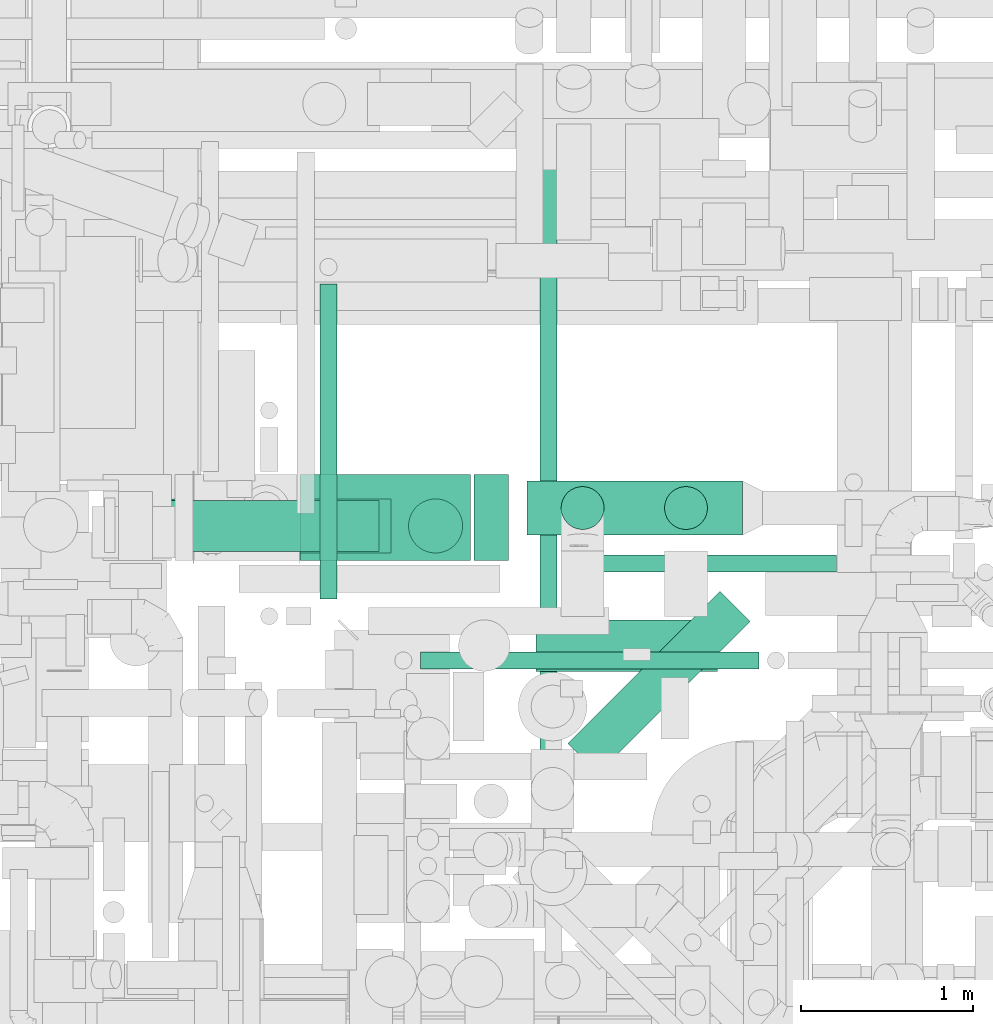
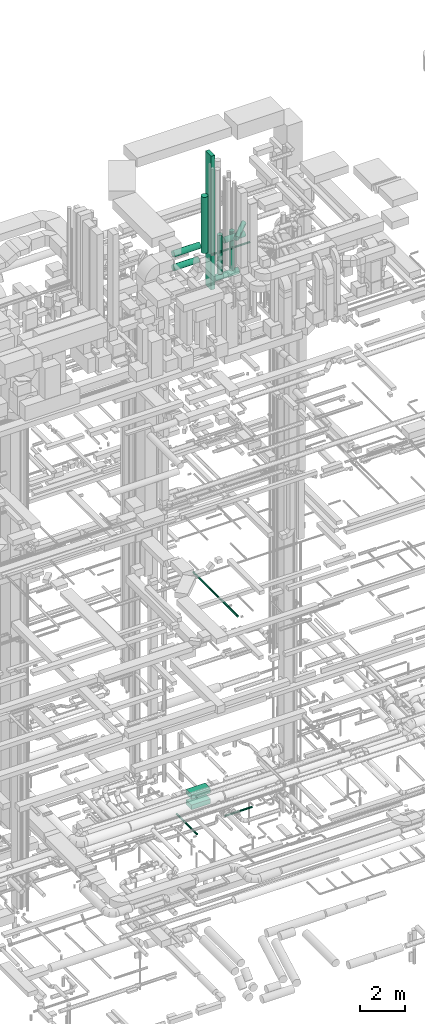
# One storey, part 58 of 337: 15 flow segments.
"""IFC2X3 building model written with IfcOpenShell, lengths in millimetres."""

from ifc_helpers import new_model, entity, si_unit, converted_unit, derived_unit, direction, frame, origin, origin_2d_with_axis, place, context, subcontext, project, spatial, rectangle, circle, extrude, type_object, element, save


model = new_model("IFC2X3")

# Units and contexts
model_context = context("Model", 3, precision=0.01, world=origin(), true_north=direction((6.12303176911189e-17, 1.0)))
body_context = subcontext(model_context, "Body", "Model", "MODEL_VIEW")
ifc_project = project(units=[si_unit("LENGTHUNIT", "METRE", prefix="MILLI"), si_unit("AREAUNIT", "SQUARE_METRE"), si_unit("VOLUMEUNIT", "CUBIC_METRE"), converted_unit("PLANEANGLEUNIT", "DEGREE", entity("IfcRatioMeasure", 0.0174532925199433), si_unit("PLANEANGLEUNIT", "RADIAN"), dimensions=[0, 0, 0, 0, 0, 0, 0]), si_unit("MASSUNIT", "GRAM", prefix="KILO"), derived_unit("MASSDENSITYUNIT", [(si_unit("MASSUNIT", "GRAM", prefix="KILO"), 1), (si_unit("LENGTHUNIT", "METRE"), -3)]), derived_unit("MOMENTOFINERTIAUNIT", [(si_unit("LENGTHUNIT", "METRE"), 4)]), si_unit("TIMEUNIT", "SECOND"), si_unit("FREQUENCYUNIT", "HERTZ"), si_unit("THERMODYNAMICTEMPERATUREUNIT", "DEGREE_CELSIUS"), derived_unit("THERMALTRANSMITTANCEUNIT", [(si_unit("MASSUNIT", "GRAM", prefix="KILO"), 1), (si_unit("THERMODYNAMICTEMPERATUREUNIT", "KELVIN"), -1), (si_unit("TIMEUNIT", "SECOND"), -3)]), derived_unit("VOLUMETRICFLOWRATEUNIT", [(si_unit("LENGTHUNIT", "METRE"), 3), (si_unit("TIMEUNIT", "SECOND"), -1)]), derived_unit("MASSFLOWRATEUNIT", [(si_unit("MASSUNIT", "GRAM", prefix="KILO"), 1), (si_unit("TIMEUNIT", "SECOND"), -1)]), derived_unit("ROTATIONALFREQUENCYUNIT", [(si_unit("TIMEUNIT", "SECOND"), -1)]), si_unit("ELECTRICCURRENTUNIT", "AMPERE"), si_unit("ELECTRICVOLTAGEUNIT", "VOLT"), si_unit("POWERUNIT", "WATT"), si_unit("FORCEUNIT", "NEWTON", prefix="KILO"), si_unit("ILLUMINANCEUNIT", "LUX"), si_unit("LUMINOUSFLUXUNIT", "LUMEN"), si_unit("LUMINOUSINTENSITYUNIT", "CANDELA"), derived_unit("USERDEFINED", [(si_unit("MASSUNIT", "GRAM", prefix="KILO"), -1), (si_unit("LENGTHUNIT", "METRE"), -2), (si_unit("TIMEUNIT", "SECOND"), 3), (si_unit("LUMINOUSFLUXUNIT", "LUMEN"), 1)]), derived_unit("LINEARVELOCITYUNIT", [(si_unit("LENGTHUNIT", "METRE"), 1), (si_unit("TIMEUNIT", "SECOND"), -1)]), si_unit("PRESSUREUNIT", "PASCAL"), derived_unit("USERDEFINED", [(si_unit("LENGTHUNIT", "METRE"), -2), (si_unit("MASSUNIT", "GRAM", prefix="KILO"), 1), (si_unit("TIMEUNIT", "SECOND"), -2)]), derived_unit("LINEARFORCEUNIT", [(si_unit("MASSUNIT", "GRAM", prefix="KILO"), 1), (si_unit("LENGTHUNIT", "METRE"), 1), (si_unit("TIMEUNIT", "SECOND"), -2), (si_unit("LENGTHUNIT", "METRE"), -1)]), derived_unit("PLANARFORCEUNIT", [(si_unit("MASSUNIT", "GRAM", prefix="KILO"), 1), (si_unit("LENGTHUNIT", "METRE"), 1), (si_unit("TIMEUNIT", "SECOND"), -2), (si_unit("LENGTHUNIT", "METRE"), -2)])], contexts=[model_context])

# Site, building, storey
site_placement = place(None, origin())
site = spatial("IfcSite", under=ifc_project, at=site_placement, CompositionType="ELEMENT")
building_placement = place(site_placement, origin())
building = spatial("IfcBuilding", under=site, at=building_placement, CompositionType="ELEMENT")
storey_placement = place(building_placement, origin())
storey = spatial("IfcBuildingStorey", under=building, at=storey_placement, CompositionType="ELEMENT", Elevation=0.0)

# Flow segments
duct_segment_type_1 = type_object("IfcDuctSegmentType", PredefinedType="NOTDEFINED")
flow_segment_1_placement = place(storey_placement, frame((55863.0, 12689.46, 28400.0)))
element("IfcFlowSegment", 1, at=flow_segment_1_placement, inside=storey, type_object=duct_segment_type_1, context=body_context, shape_type="SweptSolid", body=[
    extrude(rectangle(XDim=200.000000000007, YDim=500.000000000001, at=origin_2d_with_axis()), frame((100.0, 250.0, 0.0), z_axis=(0.0, 0.0, 1.0), x_axis=(-1.0, 0.0, 0.0)), (0.0, 0.0, 1.0), 7300.22872999999),
])
for number, where in (
    (2, (54850.11, 12689.46, 975.0)),
    (3, (54850.11, 12689.46, 400.0)),
):
    element("IfcFlowSegment", number, at=place(storey_placement, frame(where)), inside=storey, type_object=duct_segment_type_1, context=body_context, shape_type="SweptSolid", body=[
        extrude(rectangle(XDim=992.88861499988, YDim=500.000000000001, at=origin_2d_with_axis()), frame((496.44, 250.0, 0.0), z_axis=(0.0, 0.0, 1.0), x_axis=(-1.0, 0.0, 0.0)), (0.0, 0.0, 1.0), 250.0),
    ])
duct_segment_type_2 = type_object("IfcDuctSegmentType", PredefinedType="NOTDEFINED")
flow_segment_2_placement = place(storey_placement, frame((56573.85, 12619.48, -571.6)))
element("IfcFlowSegment", 4, at=flow_segment_2_placement, inside=storey, type_object=duct_segment_type_2, context=body_context, shape_type="SweptSolid", body=[
    extrude(circle(Radius=50.0, at=origin_2d_with_axis()), frame((0.0, 51.6, 51.6), z_axis=(1.0, 0.0, 0.0), x_axis=(0.0, 1.0, 0.0)), (0.0, 0.0, 1.0), 1400.35763000001),
])
flow_segment_3_placement = place(storey_placement, frame((54962.63, 12463.56, -901.6)))
element("IfcFlowSegment", 5, at=flow_segment_3_placement, inside=storey, type_object=duct_segment_type_2, context=body_context, shape_type="SweptSolid", body=[
    extrude(circle(Radius=50.0, at=origin_2d_with_axis()), frame((51.6, 0.0, 51.6), z_axis=(0.0, 1.0, 0.0), x_axis=(1.0, 0.0, 0.0)), (0.0, 0.0, 1.0), 1834.83617000007),
])
flow_segment_4_placement = place(storey_placement, frame((56244.01, 11043.29, 11398.4)))
element("IfcFlowSegment", 6, at=flow_segment_4_placement, inside=storey, type_object=duct_segment_type_2, context=body_context, shape_type="SweptSolid", body=[
    extrude(circle(Radius=50.0, at=origin_2d_with_axis()), frame((51.6, 0.0, 51.6), z_axis=(0.0, 1.0, 0.0), x_axis=(-1.0, 0.0, 0.0)), (0.0, 0.0, 1.0), 3995.00000000009),
])
flow_segment_5_placement = place(storey_placement, frame((54010.28, 12730.37, 30740.9)))
element("IfcFlowSegment", 7, at=flow_segment_5_placement, inside=storey, type_object=duct_segment_type_2, context=body_context, shape_type="SweptSolid", body=[
    extrude(circle(Radius=157.5, at=origin_2d_with_axis()), frame((0.0, 159.1, 159.1), z_axis=(1.0, 0.0, 0.0), x_axis=(0.0, -1.0, 0.0)), (0.0, 0.0, 1.0), 1369.138095),
])
flow_segment_6_placement = place(storey_placement, frame((55479.42, 12730.37, 30460.51)))
element("IfcFlowSegment", 8, at=flow_segment_6_placement, inside=storey, type_object=duct_segment_type_2, context=body_context, shape_type="SweptSolid", body=[
    extrude(circle(Radius=157.5, at=origin_2d_with_axis()), frame((159.1, 159.1, 0.0), z_axis=(0.0, 0.0, 1.0), x_axis=(0.0, -1.0, 0.0)), (0.0, 0.0, 1.0), 3065.00000000001),
])
flow_segment_7_placement = place(storey_placement, frame((54010.28, 12737.87, 29993.91)))
element("IfcFlowSegment", 9, at=flow_segment_7_placement, inside=storey, type_object=duct_segment_type_2, context=body_context, shape_type="SweptSolid", body=[
    extrude(circle(Radius=150.0, at=origin_2d_with_axis()), frame((0.0, 151.6, 151.6), z_axis=(1.0, 0.0, 0.0), x_axis=(0.0, -1.0, 0.0)), (0.0, 0.0, 1.0), 1298.23809500001),
])
flow_segment_8_placement = place(storey_placement, frame((56170.78, 12834.92, 28590.9)))
element("IfcFlowSegment", 10, at=flow_segment_8_placement, inside=storey, type_object=duct_segment_type_2, context=body_context, shape_type="SweptSolid", body=[
    extrude(circle(Radius=157.5, at=origin_2d_with_axis()), frame((0.0, 159.1, 159.1), z_axis=(1.0, 0.0, 0.0), x_axis=(0.0, 1.0, 0.0)), (0.0, 0.0, 1.0), 1256.87500000005),
])
flow_segment_9_placement = place(storey_placement, frame((56368.56, 12867.42, 28927.5)))
element("IfcFlowSegment", 11, at=flow_segment_9_placement, inside=storey, type_object=duct_segment_type_2, context=body_context, shape_type="SweptSolid", body=[
    extrude(circle(Radius=125.0, at=origin_2d_with_axis()), frame((126.6, 126.6, 0.0), z_axis=(0.0, 0.0, 1.0), x_axis=(0.0, 1.0, 0.0)), (0.0, 0.0, 1.0), 2122.50000000001),
])
flow_segment_10_placement = place(storey_placement, frame((56971.06, 12867.42, 28927.5)))
element("IfcFlowSegment", 12, at=flow_segment_10_placement, inside=storey, type_object=duct_segment_type_2, context=body_context, shape_type="SweptSolid", body=[
    extrude(circle(Radius=125.0, at=origin_2d_with_axis()), frame((126.6, 126.6, 0.0), z_axis=(0.0, 0.0, 1.0), x_axis=(0.0, -1.0, 0.0)), (0.0, 0.0, 1.0), 2122.5),
])
flow_segment_11_placement = place(storey_placement, frame((56222.5, 12040.73, 31148.4)))
element("IfcFlowSegment", 13, at=flow_segment_11_placement, inside=storey, type_object=duct_segment_type_2, context=body_context, shape_type="SweptSolid", body=[
    extrude(circle(Radius=150.0, at=origin_2d_with_axis()), frame((0.0, 151.6, 151.6), z_axis=(1.0, 0.0, 0.0), x_axis=(0.0, -1.0, 0.0)), (0.0, 0.0, 1.0), 1060.00000000003),
])
flow_segment_12_placement = place(storey_placement, frame((55551.0, 12054.04, 30748.4)))
element("IfcFlowSegment", 14, at=flow_segment_12_placement, inside=storey, type_object=duct_segment_type_2, context=body_context, shape_type="SweptSolid", body=[
    extrude(circle(Radius=50.0, at=origin_2d_with_axis()), frame((0.0, 51.6, 51.6), z_axis=(1.0, 0.0, 0.0), x_axis=(0.0, -1.0, 0.0)), (0.0, 0.0, 1.0), 1970.49999999999),
])
flow_segment_13_placement = place(storey_placement, frame((56407.29, 11444.33, 31573.4)))
element("IfcFlowSegment", 15, at=flow_segment_13_placement, inside=storey, type_object=duct_segment_type_2, context=body_context, shape_type="SweptSolid", body=[
    extrude(circle(Radius=125.0, at=origin_2d_with_axis()), frame((89.98, 89.98, 126.6), z_axis=(0.707106781186548, 0.707106781186547, 0.0), x_axis=(0.707106781186547, -0.707106781186548, 0.0)), (0.0, 0.0, 1.0), 1253.25134918224),
])

save(model, "model.ifc")
